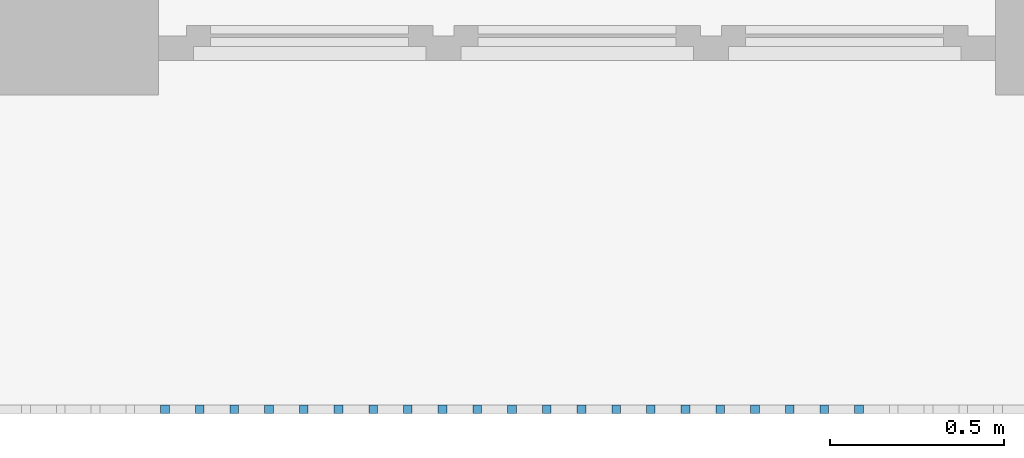
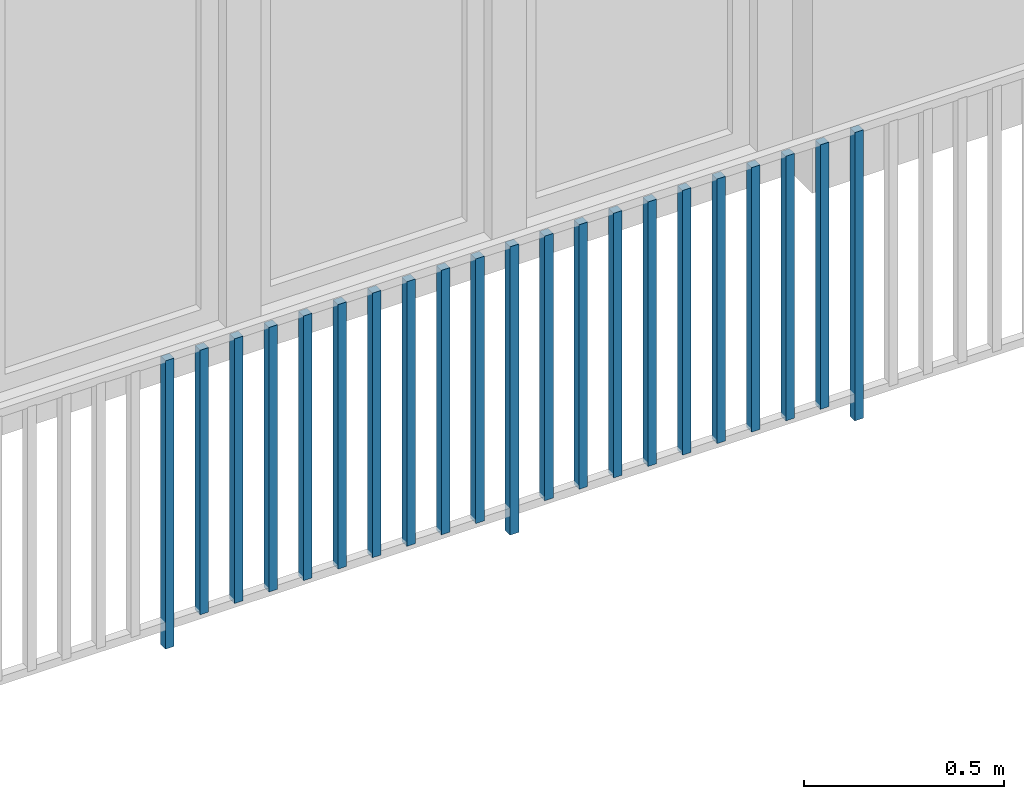
# One storey, part 27 of 48: 21 building element parts, 1 element without a shape of its own.
"""IFC4 building model written with IfcOpenShell, lengths in metres."""

from ifc_helpers import new_model, entity, si_unit, converted_unit, derived_unit, direction, frame, origin_with_axes, place, context, subcontext, project, spatial, polygons, material, type_object, element, aggregate, save


model = new_model("IFC4")

# Units and contexts
model_context = context("Model", 3, precision=1e-05, world=origin_with_axes(), true_north=direction((0.0, 1.0)))
body_context = subcontext(model_context, "Body", "Model", "MODEL_VIEW")
ifc_project = project(units=[si_unit("LENGTHUNIT", "METRE"), si_unit("AREAUNIT", "SQUARE_METRE"), si_unit("VOLUMEUNIT", "CUBIC_METRE"), converted_unit("PLANEANGLEUNIT", "DEGREE", entity("IfcPlaneAngleMeasure", 0.0174532925199), si_unit("PLANEANGLEUNIT", "RADIAN"), dimensions=[0, 0, 0, 0, 0, 0, 0]), converted_unit("TIMEUNIT", "Year", entity("IfcTimeMeasure", 31556926.0), si_unit("TIMEUNIT", "SECOND"), dimensions=[0, 0, 1, 0, 0, 0, 0]), si_unit("MASSUNIT", "GRAM", prefix="KILO"), si_unit("THERMODYNAMICTEMPERATUREUNIT", "DEGREE_CELSIUS"), si_unit("LUMINOUSINTENSITYUNIT", "LUMEN"), si_unit("ENERGYUNIT", "JOULE", prefix="MEGA"), derived_unit("THERMALCONDUCTANCEUNIT", [(si_unit("POWERUNIT", "WATT"), 1), (si_unit("LENGTHUNIT", "METRE"), -1), (si_unit("THERMODYNAMICTEMPERATUREUNIT", "KELVIN"), -1)]), derived_unit("SPECIFICHEATCAPACITYUNIT", [(si_unit("ENERGYUNIT", "JOULE"), 1), (si_unit("MASSUNIT", "GRAM", prefix="KILO"), -1), (si_unit("THERMODYNAMICTEMPERATUREUNIT", "KELVIN"), -1)]), derived_unit("MASSDENSITYUNIT", [(si_unit("MASSUNIT", "GRAM", prefix="KILO"), 1), (si_unit("VOLUMEUNIT", "CUBIC_METRE"), -1)])], contexts=[model_context])

# Site, building, storey
site_placement = place(None, origin_with_axes())
site = spatial("IfcSite", under=ifc_project, at=site_placement, CompositionType="ELEMENT")
building_placement = place(site_placement, origin_with_axes())
building = spatial("IfcBuilding", under=site, at=building_placement, CompositionType="ELEMENT")
storey_placement = place(building_placement, frame((0.0, 0.0, 3.4), z_axis=(0.0, 0.0, 1.0), x_axis=(1.0, 0.0, 0.0)))
storey = spatial("IfcBuildingStorey", under=building, at=storey_placement, Name="1. Geschoss", CompositionType="ELEMENT", Elevation=3.4)

# Railing, building element parts
railing_type = type_object("IfcRailingType", PredefinedType="NOTDEFINED")
railing_placement = place(storey_placement, frame((10.2378006196, 9.82118776896, 0.0), z_axis=(0.0, 0.0, 1.0), x_axis=(1.0, 0.0, 0.0)))
railing = element("IfcRailing", 1, at=railing_placement, inside=storey, type_object=railing_type, PredefinedType="NOTDEFINED")
ifc_material = material()
building_element_part_1_placement = place(railing_placement, origin_with_axes())
building_element_part_1 = element("IfcBuildingElementPart", 2, at=building_element_part_1_placement, material=ifc_material, PredefinedType="NOTDEFINED", context=body_context, shape_type="Tessellation", body=[
    polygons([(-16.8988043478, -20.6625, 0.0), (-16.8988043478, -20.6375, 0.0), (-16.8988043478, -20.6375, 0.88), (-16.8988043478, -20.6625, 0.88), (-16.9238043478, -20.6625, 0.0), (-16.9238043478, -20.6375, 0.0), (-16.9238043478, -20.6375, 0.88), (-16.9238043478, -20.6625, 0.88)], [[[1, 2, 3, 4]], [[1, 5, 6, 2]], [[2, 6, 7, 3]], [[4, 3, 7, 8]], [[5, 1, 4, 8]], [[6, 5, 8, 7]]], closed=True),
])
building_element_part_2_placement = place(railing_placement, origin_with_axes())
building_element_part_2 = element("IfcBuildingElementPart", 3, at=building_element_part_2_placement, material=ifc_material, PredefinedType="NOTDEFINED", context=body_context, shape_type="Tessellation", body=[
    polygons([(-16.799326087, -20.6625, 0.07), (-16.799326087, -20.6375, 0.07), (-16.799326087, -20.6375, 0.8775), (-16.799326087, -20.6625, 0.8775), (-16.824326087, -20.6625, 0.07), (-16.824326087, -20.6375, 0.07), (-16.824326087, -20.6375, 0.8775), (-16.824326087, -20.6625, 0.8775)], [[[1, 2, 3, 4]], [[1, 5, 6, 2]], [[2, 6, 7, 3]], [[4, 3, 7, 8]], [[5, 1, 4, 8]], [[6, 5, 8, 7]]], closed=True),
])
building_element_part_3_placement = place(railing_placement, origin_with_axes())
building_element_part_3 = element("IfcBuildingElementPart", 4, at=building_element_part_3_placement, material=ifc_material, PredefinedType="NOTDEFINED", context=body_context, shape_type="Tessellation", body=[
    polygons([(-16.6998478261, -20.6625, 0.07), (-16.6998478261, -20.6375, 0.07), (-16.6998478261, -20.6375, 0.8775), (-16.6998478261, -20.6625, 0.8775), (-16.7248478261, -20.6625, 0.07), (-16.7248478261, -20.6375, 0.07), (-16.7248478261, -20.6375, 0.8775), (-16.7248478261, -20.6625, 0.8775)], [[[1, 2, 3, 4]], [[1, 5, 6, 2]], [[2, 6, 7, 3]], [[4, 3, 7, 8]], [[5, 1, 4, 8]], [[6, 5, 8, 7]]], closed=True),
])
building_element_part_4_placement = place(railing_placement, origin_with_axes())
building_element_part_4 = element("IfcBuildingElementPart", 5, at=building_element_part_4_placement, material=ifc_material, PredefinedType="NOTDEFINED", context=body_context, shape_type="Tessellation", body=[
    polygons([(-16.6003695652, -20.6625, 0.07), (-16.6003695652, -20.6375, 0.07), (-16.6003695652, -20.6375, 0.8775), (-16.6003695652, -20.6625, 0.8775), (-16.6253695652, -20.6625, 0.07), (-16.6253695652, -20.6375, 0.07), (-16.6253695652, -20.6375, 0.8775), (-16.6253695652, -20.6625, 0.8775)], [[[1, 2, 3, 4]], [[1, 5, 6, 2]], [[2, 6, 7, 3]], [[4, 3, 7, 8]], [[5, 1, 4, 8]], [[6, 5, 8, 7]]], closed=True),
])
building_element_part_5_placement = place(railing_placement, origin_with_axes())
building_element_part_5 = element("IfcBuildingElementPart", 6, at=building_element_part_5_placement, material=ifc_material, PredefinedType="NOTDEFINED", context=body_context, shape_type="Tessellation", body=[
    polygons([(-16.5008913043, -20.6625, 0.07), (-16.5008913043, -20.6375, 0.07), (-16.5008913043, -20.6375, 0.8775), (-16.5008913043, -20.6625, 0.8775), (-16.5258913043, -20.6625, 0.07), (-16.5258913043, -20.6375, 0.07), (-16.5258913043, -20.6375, 0.8775), (-16.5258913043, -20.6625, 0.8775)], [[[1, 2, 3, 4]], [[1, 5, 6, 2]], [[2, 6, 7, 3]], [[4, 3, 7, 8]], [[5, 1, 4, 8]], [[6, 5, 8, 7]]], closed=True),
])
building_element_part_6_placement = place(railing_placement, origin_with_axes())
building_element_part_6 = element("IfcBuildingElementPart", 7, at=building_element_part_6_placement, material=ifc_material, PredefinedType="NOTDEFINED", context=body_context, shape_type="Tessellation", body=[
    polygons([(-16.4014130435, -20.6625, 0.07), (-16.4014130435, -20.6375, 0.07), (-16.4014130435, -20.6375, 0.8775), (-16.4014130435, -20.6625, 0.8775), (-16.4264130435, -20.6625, 0.07), (-16.4264130435, -20.6375, 0.07), (-16.4264130435, -20.6375, 0.8775), (-16.4264130435, -20.6625, 0.8775)], [[[1, 2, 3, 4]], [[1, 5, 6, 2]], [[2, 6, 7, 3]], [[4, 3, 7, 8]], [[5, 1, 4, 8]], [[6, 5, 8, 7]]], closed=True),
])
building_element_part_7_placement = place(railing_placement, origin_with_axes())
building_element_part_7 = element("IfcBuildingElementPart", 8, at=building_element_part_7_placement, material=ifc_material, PredefinedType="NOTDEFINED", context=body_context, shape_type="Tessellation", body=[
    polygons([(-16.3019347826, -20.6625, 0.07), (-16.3019347826, -20.6375, 0.07), (-16.3019347826, -20.6375, 0.8775), (-16.3019347826, -20.6625, 0.8775), (-16.3269347826, -20.6625, 0.07), (-16.3269347826, -20.6375, 0.07), (-16.3269347826, -20.6375, 0.8775), (-16.3269347826, -20.6625, 0.8775)], [[[1, 2, 3, 4]], [[1, 5, 6, 2]], [[2, 6, 7, 3]], [[4, 3, 7, 8]], [[5, 1, 4, 8]], [[6, 5, 8, 7]]], closed=True),
])
building_element_part_8_placement = place(railing_placement, origin_with_axes())
building_element_part_8 = element("IfcBuildingElementPart", 9, at=building_element_part_8_placement, material=ifc_material, PredefinedType="NOTDEFINED", context=body_context, shape_type="Tessellation", body=[
    polygons([(-16.2024565217, -20.6625, 0.07), (-16.2024565217, -20.6375, 0.07), (-16.2024565217, -20.6375, 0.8775), (-16.2024565217, -20.6625, 0.8775), (-16.2274565217, -20.6625, 0.07), (-16.2274565217, -20.6375, 0.07), (-16.2274565217, -20.6375, 0.8775), (-16.2274565217, -20.6625, 0.8775)], [[[1, 2, 3, 4]], [[1, 5, 6, 2]], [[2, 6, 7, 3]], [[4, 3, 7, 8]], [[5, 1, 4, 8]], [[6, 5, 8, 7]]], closed=True),
])
building_element_part_9_placement = place(railing_placement, origin_with_axes())
building_element_part_9 = element("IfcBuildingElementPart", 10, at=building_element_part_9_placement, material=ifc_material, PredefinedType="NOTDEFINED", context=body_context, shape_type="Tessellation", body=[
    polygons([(-16.1029782609, -20.6625, 0.07), (-16.1029782609, -20.6375, 0.07), (-16.1029782609, -20.6375, 0.8775), (-16.1029782609, -20.6625, 0.8775), (-16.1279782609, -20.6625, 0.07), (-16.1279782609, -20.6375, 0.07), (-16.1279782609, -20.6375, 0.8775), (-16.1279782609, -20.6625, 0.8775)], [[[1, 2, 3, 4]], [[1, 5, 6, 2]], [[2, 6, 7, 3]], [[4, 3, 7, 8]], [[5, 1, 4, 8]], [[6, 5, 8, 7]]], closed=True),
])
building_element_part_10_placement = place(railing_placement, origin_with_axes())
building_element_part_10 = element("IfcBuildingElementPart", 11, at=building_element_part_10_placement, material=ifc_material, PredefinedType="NOTDEFINED", context=body_context, shape_type="Tessellation", body=[
    polygons([(-16.0035, -20.6625, 0.07), (-16.0035, -20.6375, 0.07), (-16.0035, -20.6375, 0.8775), (-16.0035, -20.6625, 0.8775), (-16.0285, -20.6625, 0.07), (-16.0285, -20.6375, 0.07), (-16.0285, -20.6375, 0.8775), (-16.0285, -20.6625, 0.8775)], [[[1, 2, 3, 4]], [[1, 5, 6, 2]], [[2, 6, 7, 3]], [[4, 3, 7, 8]], [[5, 1, 4, 8]], [[6, 5, 8, 7]]], closed=True),
])
building_element_part_11_placement = place(railing_placement, origin_with_axes())
building_element_part_11 = element("IfcBuildingElementPart", 12, at=building_element_part_11_placement, material=ifc_material, PredefinedType="NOTDEFINED", context=body_context, shape_type="Tessellation", body=[
    polygons([(-15.9040217391, -20.6625, 0.0), (-15.9040217391, -20.6375, 0.0), (-15.9040217391, -20.6375, 0.88), (-15.9040217391, -20.6625, 0.88), (-15.9290217391, -20.6625, 0.0), (-15.9290217391, -20.6375, 0.0), (-15.9290217391, -20.6375, 0.88), (-15.9290217391, -20.6625, 0.88)], [[[1, 2, 3, 4]], [[1, 5, 6, 2]], [[2, 6, 7, 3]], [[4, 3, 7, 8]], [[5, 1, 4, 8]], [[6, 5, 8, 7]]], closed=True),
])
building_element_part_12_placement = place(railing_placement, origin_with_axes())
building_element_part_12 = element("IfcBuildingElementPart", 13, at=building_element_part_12_placement, material=ifc_material, PredefinedType="NOTDEFINED", context=body_context, shape_type="Tessellation", body=[
    polygons([(-15.8045434783, -20.6625, 0.07), (-15.8045434783, -20.6375, 0.07), (-15.8045434783, -20.6375, 0.8775), (-15.8045434783, -20.6625, 0.8775), (-15.8295434783, -20.6625, 0.07), (-15.8295434783, -20.6375, 0.07), (-15.8295434783, -20.6375, 0.8775), (-15.8295434783, -20.6625, 0.8775)], [[[1, 2, 3, 4]], [[1, 5, 6, 2]], [[2, 6, 7, 3]], [[4, 3, 7, 8]], [[5, 1, 4, 8]], [[6, 5, 8, 7]]], closed=True),
])
building_element_part_13_placement = place(railing_placement, origin_with_axes())
building_element_part_13 = element("IfcBuildingElementPart", 14, at=building_element_part_13_placement, material=ifc_material, PredefinedType="NOTDEFINED", context=body_context, shape_type="Tessellation", body=[
    polygons([(-15.7050652174, -20.6625, 0.07), (-15.7050652174, -20.6375, 0.07), (-15.7050652174, -20.6375, 0.8775), (-15.7050652174, -20.6625, 0.8775), (-15.7300652174, -20.6625, 0.07), (-15.7300652174, -20.6375, 0.07), (-15.7300652174, -20.6375, 0.8775), (-15.7300652174, -20.6625, 0.8775)], [[[1, 2, 3, 4]], [[1, 5, 6, 2]], [[2, 6, 7, 3]], [[4, 3, 7, 8]], [[5, 1, 4, 8]], [[6, 5, 8, 7]]], closed=True),
])
building_element_part_14_placement = place(railing_placement, origin_with_axes())
building_element_part_14 = element("IfcBuildingElementPart", 15, at=building_element_part_14_placement, material=ifc_material, PredefinedType="NOTDEFINED", context=body_context, shape_type="Tessellation", body=[
    polygons([(-15.6055869565, -20.6625, 0.07), (-15.6055869565, -20.6375, 0.07), (-15.6055869565, -20.6375, 0.8775), (-15.6055869565, -20.6625, 0.8775), (-15.6305869565, -20.6625, 0.07), (-15.6305869565, -20.6375, 0.07), (-15.6305869565, -20.6375, 0.8775), (-15.6305869565, -20.6625, 0.8775)], [[[1, 2, 3, 4]], [[1, 5, 6, 2]], [[2, 6, 7, 3]], [[4, 3, 7, 8]], [[5, 1, 4, 8]], [[6, 5, 8, 7]]], closed=True),
])
building_element_part_15_placement = place(railing_placement, origin_with_axes())
building_element_part_15 = element("IfcBuildingElementPart", 16, at=building_element_part_15_placement, material=ifc_material, PredefinedType="NOTDEFINED", context=body_context, shape_type="Tessellation", body=[
    polygons([(-15.5061086957, -20.6625, 0.07), (-15.5061086957, -20.6375, 0.07), (-15.5061086957, -20.6375, 0.8775), (-15.5061086957, -20.6625, 0.8775), (-15.5311086957, -20.6625, 0.07), (-15.5311086957, -20.6375, 0.07), (-15.5311086957, -20.6375, 0.8775), (-15.5311086957, -20.6625, 0.8775)], [[[1, 2, 3, 4]], [[1, 5, 6, 2]], [[2, 6, 7, 3]], [[4, 3, 7, 8]], [[5, 1, 4, 8]], [[6, 5, 8, 7]]], closed=True),
])
building_element_part_16_placement = place(railing_placement, origin_with_axes())
building_element_part_16 = element("IfcBuildingElementPart", 17, at=building_element_part_16_placement, material=ifc_material, PredefinedType="NOTDEFINED", context=body_context, shape_type="Tessellation", body=[
    polygons([(-15.4066304348, -20.6625, 0.07), (-15.4066304348, -20.6375, 0.07), (-15.4066304348, -20.6375, 0.8775), (-15.4066304348, -20.6625, 0.8775), (-15.4316304348, -20.6625, 0.07), (-15.4316304348, -20.6375, 0.07), (-15.4316304348, -20.6375, 0.8775), (-15.4316304348, -20.6625, 0.8775)], [[[1, 2, 3, 4]], [[1, 5, 6, 2]], [[2, 6, 7, 3]], [[4, 3, 7, 8]], [[5, 1, 4, 8]], [[6, 5, 8, 7]]], closed=True),
])
building_element_part_17_placement = place(railing_placement, origin_with_axes())
building_element_part_17 = element("IfcBuildingElementPart", 18, at=building_element_part_17_placement, material=ifc_material, PredefinedType="NOTDEFINED", context=body_context, shape_type="Tessellation", body=[
    polygons([(-15.3071521739, -20.6625, 0.07), (-15.3071521739, -20.6375, 0.07), (-15.3071521739, -20.6375, 0.8775), (-15.3071521739, -20.6625, 0.8775), (-15.3321521739, -20.6625, 0.07), (-15.3321521739, -20.6375, 0.07), (-15.3321521739, -20.6375, 0.8775), (-15.3321521739, -20.6625, 0.8775)], [[[1, 2, 3, 4]], [[1, 5, 6, 2]], [[2, 6, 7, 3]], [[4, 3, 7, 8]], [[5, 1, 4, 8]], [[6, 5, 8, 7]]], closed=True),
])
building_element_part_18_placement = place(railing_placement, origin_with_axes())
building_element_part_18 = element("IfcBuildingElementPart", 19, at=building_element_part_18_placement, material=ifc_material, PredefinedType="NOTDEFINED", context=body_context, shape_type="Tessellation", body=[
    polygons([(-15.207673913, -20.6625, 0.07), (-15.207673913, -20.6375, 0.07), (-15.207673913, -20.6375, 0.8775), (-15.207673913, -20.6625, 0.8775), (-15.232673913, -20.6625, 0.07), (-15.232673913, -20.6375, 0.07), (-15.232673913, -20.6375, 0.8775), (-15.232673913, -20.6625, 0.8775)], [[[1, 2, 3, 4]], [[1, 5, 6, 2]], [[2, 6, 7, 3]], [[4, 3, 7, 8]], [[5, 1, 4, 8]], [[6, 5, 8, 7]]], closed=True),
])
building_element_part_19_placement = place(railing_placement, origin_with_axes())
building_element_part_19 = element("IfcBuildingElementPart", 20, at=building_element_part_19_placement, material=ifc_material, PredefinedType="NOTDEFINED", context=body_context, shape_type="Tessellation", body=[
    polygons([(-15.1081956522, -20.6625, 0.07), (-15.1081956522, -20.6375, 0.07), (-15.1081956522, -20.6375, 0.8775), (-15.1081956522, -20.6625, 0.8775), (-15.1331956522, -20.6625, 0.07), (-15.1331956522, -20.6375, 0.07), (-15.1331956522, -20.6375, 0.8775), (-15.1331956522, -20.6625, 0.8775)], [[[1, 2, 3, 4]], [[1, 5, 6, 2]], [[2, 6, 7, 3]], [[4, 3, 7, 8]], [[5, 1, 4, 8]], [[6, 5, 8, 7]]], closed=True),
])
building_element_part_20_placement = place(railing_placement, origin_with_axes())
building_element_part_20 = element("IfcBuildingElementPart", 21, at=building_element_part_20_placement, material=ifc_material, PredefinedType="NOTDEFINED", context=body_context, shape_type="Tessellation", body=[
    polygons([(-15.0087173913, -20.6625, 0.07), (-15.0087173913, -20.6375, 0.07), (-15.0087173913, -20.6375, 0.8775), (-15.0087173913, -20.6625, 0.8775), (-15.0337173913, -20.6625, 0.07), (-15.0337173913, -20.6375, 0.07), (-15.0337173913, -20.6375, 0.8775), (-15.0337173913, -20.6625, 0.8775)], [[[1, 2, 3, 4]], [[1, 5, 6, 2]], [[2, 6, 7, 3]], [[4, 3, 7, 8]], [[5, 1, 4, 8]], [[6, 5, 8, 7]]], closed=True),
])
building_element_part_21_placement = place(railing_placement, origin_with_axes())
building_element_part_21 = element("IfcBuildingElementPart", 22, at=building_element_part_21_placement, material=ifc_material, PredefinedType="NOTDEFINED", context=body_context, shape_type="Tessellation", body=[
    polygons([(-14.9092391304, -20.6625, 0.0), (-14.9092391304, -20.6375, 0.0), (-14.9092391304, -20.6375, 0.88), (-14.9092391304, -20.6625, 0.88), (-14.9342391304, -20.6625, 0.0), (-14.9342391304, -20.6375, 0.0), (-14.9342391304, -20.6375, 0.88), (-14.9342391304, -20.6625, 0.88)], [[[1, 2, 3, 4]], [[1, 5, 6, 2]], [[2, 6, 7, 3]], [[4, 3, 7, 8]], [[5, 1, 4, 8]], [[6, 5, 8, 7]]], closed=True),
])
aggregate(railing, [building_element_part_1, building_element_part_2, building_element_part_3, building_element_part_4, building_element_part_5, building_element_part_6, building_element_part_7, building_element_part_8, building_element_part_9, building_element_part_10, building_element_part_11, building_element_part_12, building_element_part_13, building_element_part_14, building_element_part_15, building_element_part_16, building_element_part_17, building_element_part_18, building_element_part_19, building_element_part_20, building_element_part_21])

save(model, "model.ifc")
